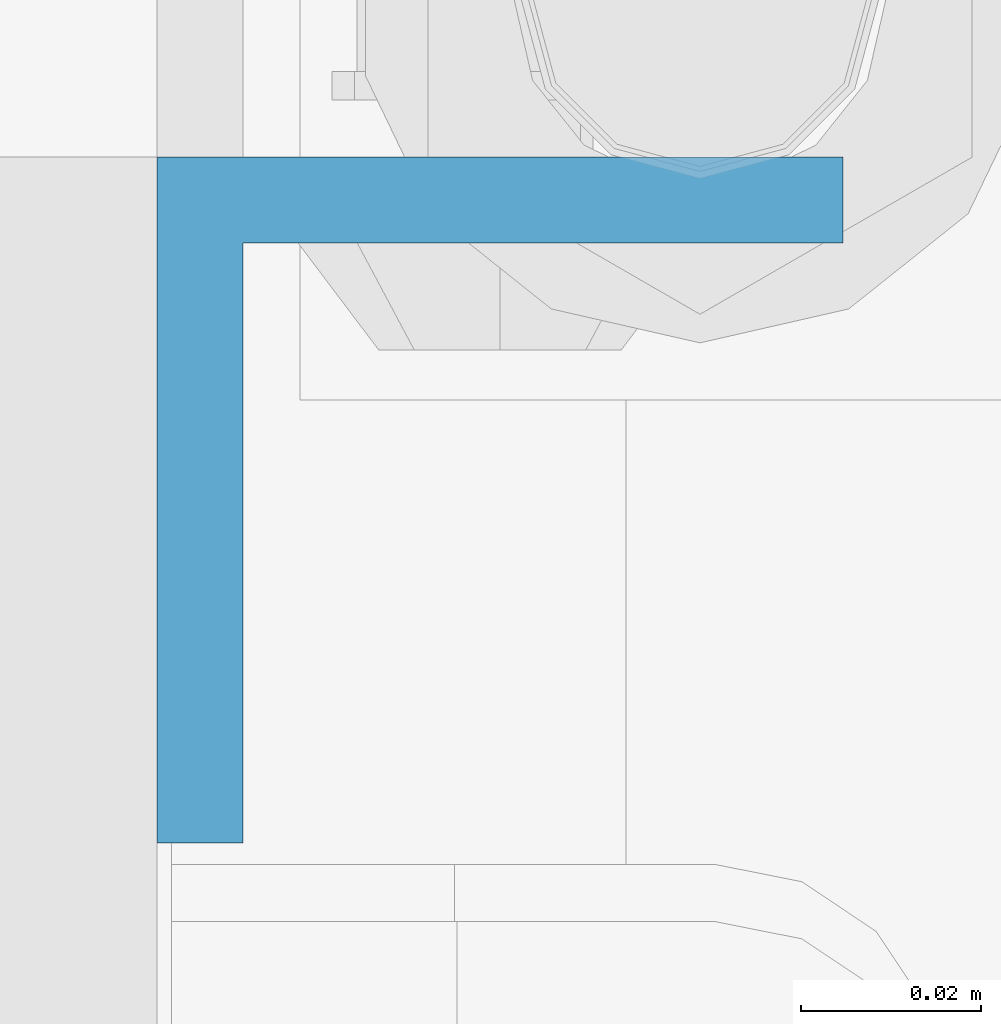
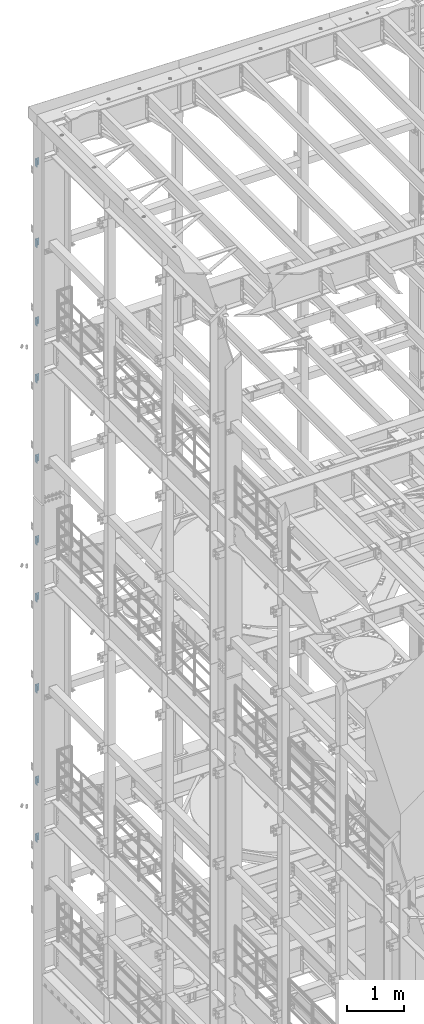
# One storey, part 853 of 1876: 10 columns, 2 elements without a shape of their own.
"""IFC2X3 building model written with IfcOpenShell, lengths in millimetres."""

import ifcopenshell
import ifcopenshell.guid

model = None  # the IFC model being written
_history = None  # IfcOwnerHistory: only IFC2X3 demands one
_inside = {}  # id of a spatial element -> (the spatial element, [elements in it])
_under = {}  # id of a project, library or spatial element -> (it, [spatial elements below it])
_declared = {}  # id of a project -> (the project, [libraries it declares])
_typed = {}  # id of a type object -> (the type object, [elements of that type])
_made_of = {}  # id of a material, layer set ... -> (it, [elements and type objects made of it])


def new_model(schema):
    """Start an empty IFC model of exactly this schema.

    Asked for "IFC4X3", IfcOpenShell would pick the latest addendum, in which some entities
    have other attributes; the version numbers below select the first issue.
    IFC2X3 requires an IfcOwnerHistory on every rooted entity: one is made here for all.
    """
    global model, _history
    if schema == "IFC4X3":
        model = ifcopenshell.file(schema_version=(4, 3, 0, 0))
    else:
        model = ifcopenshell.file(schema=schema)
    _inside.clear()
    _under.clear()
    _declared.clear()
    _typed.clear()
    _made_of.clear()
    _history = None
    if model.schema == "IFC2X3":
        org = make("IfcOrganization", Name="unknown")
        user = make(
            "IfcPersonAndOrganization",
            ThePerson=make("IfcPerson", FamilyName="unknown"),
            TheOrganization=org,
        )
        app = make(
            "IfcApplication",
            ApplicationDeveloper=org,
            Version="unknown",
            ApplicationFullName="unknown",
            ApplicationIdentifier="unknown",
        )
        _history = make(
            "IfcOwnerHistory",
            OwningUser=user,
            OwningApplication=app,
            ChangeAction="ADDED",
            CreationDate=0,
        )
    return model


def make(cls, **values):
    """One entity of the class cls with the attributes given. An attribute that is None is left unset."""
    return model.create_entity(
        cls, **{name: value for name, value in values.items() if value is not None}
    )


def rooted(cls, **values):
    """An entity with a GlobalId (a new one), such as an element, a storey or a relation."""
    return make(cls, GlobalId=ifcopenshell.guid.new(), OwnerHistory=_history, **values)


def si_unit(unit_type, name, prefix=None):
    """IfcSIUnit, for example si_unit("LENGTHUNIT", "METRE", prefix="MILLI")."""
    return make("IfcSIUnit", UnitType=unit_type, Prefix=prefix, Name=name)


def assignment(units):
    """IfcUnitAssignment: the units of a project."""
    return None if units is None else make("IfcUnitAssignment", Units=units)


def point(xyz):
    """IfcCartesianPoint."""
    return None if xyz is None else make("IfcCartesianPoint", Coordinates=xyz)


def direction(xyz):
    """IfcDirection."""
    return None if xyz is None else make("IfcDirection", DirectionRatios=xyz)


def frame(location, z_axis=None, x_axis=None):
    """IfcAxis2Placement3D, a coordinate frame: its origin and axes. An axis left out is left unset."""
    return make(
        "IfcAxis2Placement3D",
        Location=point(location),
        Axis=direction(z_axis),
        RefDirection=direction(x_axis),
    )


def origin_with_axes():
    """The frame at (0, 0, 0) with the z axis (0, 0, 1) and the x axis (1, 0, 0) written out."""
    return frame((0.0, 0.0, 0.0), z_axis=(0.0, 0.0, 1.0), x_axis=(1.0, 0.0, 0.0))


def place(relative_to, where):
    """IfcLocalPlacement: puts the frame where relative to a parent placement (None: the world)."""
    return make(
        "IfcLocalPlacement", PlacementRelTo=relative_to, RelativePlacement=where
    )


def context(
    kind, dimensions, precision=None, world=None, true_north=None, identifier=None
):
    """IfcGeometricRepresentationContext, for example the 3D "Model" context."""
    return make(
        "IfcGeometricRepresentationContext",
        ContextIdentifier=identifier,
        ContextType=kind,
        CoordinateSpaceDimension=dimensions,
        Precision=precision,
        WorldCoordinateSystem=world,
        TrueNorth=true_north,
    )


def subcontext(parent, identifier, kind, view, scale=None):
    """IfcGeometricRepresentationSubContext, for example "Body" below "Model"."""
    return make(
        "IfcGeometricRepresentationSubContext",
        ContextIdentifier=identifier,
        ContextType=kind,
        ParentContext=parent,
        TargetScale=scale,
        TargetView=view,
    )


def project(units=None, contexts=None):
    """IfcProject with its units and contexts."""
    return rooted(
        "IfcProject",
        Name="project",
        RepresentationContexts=contexts,
        UnitsInContext=assignment(units),
    )


def spatial(cls, under=None, at=None, **own):
    """A site, building, storey or space (cls), placed at a placement, below another one or the project."""
    s = rooted(cls, ObjectPlacement=at, **own)
    if under is not None:
        _under.setdefault(under.id(), (under, []))[1].append(s)
    return s


def faces_of(points, faces, orient=None, outer=None):
    """IfcFace entities. A face is a list of loops; a loop is a list of indices into points, from 0.

    orient and outer hold one flag for each loop. By default every Orientation is true, the
    first loop of a face is its IfcFaceOuterBound and the others are IfcFaceBound.
    """
    made = []
    for i, loops in enumerate(faces):
        bounds = []
        for j, loop in enumerate(loops):
            is_outer = j == 0 if outer is None else outer[i][j]
            bounds.append(
                make(
                    "IfcFaceOuterBound" if is_outer else "IfcFaceBound",
                    Bound=make("IfcPolyLoop", Polygon=[points[k] for k in loop]),
                    Orientation=True if orient is None else orient[i][j],
                )
            )
        made.append(make("IfcFace", Bounds=bounds))
    return made


def faceted_brep(points, faces, orient=None, outer=None, voids=None):
    """IfcFacetedBrep: a solid bounded by flat faces; with voids (closed shells), ...WithVoids."""
    shared = [point(p) for p in points]
    hull = make("IfcClosedShell", CfsFaces=faces_of(shared, faces, orient, outer))
    if voids is None:
        return make("IfcFacetedBrep", Outer=hull)
    return make(
        "IfcFacetedBrepWithVoids",
        Outer=hull,
        Voids=[
            make(cls, CfsFaces=faces_of(shared, fs, o, b)) for cls, fs, o, b in voids
        ],
    )


def shape(context_of_items, identifier, shape_type, items):
    """IfcShapeRepresentation: the items that make up one representation, for example the "Body"."""
    return make(
        "IfcShapeRepresentation",
        ContextOfItems=context_of_items,
        RepresentationIdentifier=identifier,
        RepresentationType=shape_type,
        Items=items,
    )


def material(Name=None, Category=None):
    """IfcMaterial."""
    return make("IfcMaterial", Name=Name, Category=Category)


def made_of(thing, what):
    """Note that an element or type object is made of a material, layer set ...; save() writes the relation."""
    if what is not None:
        _made_of.setdefault(what.id(), (what, []))[1].append(thing)
    return thing


def type_object(cls, material=None, **own):
    """A type object (cls), such as IfcWallType, which elements share."""
    return made_of(rooted(cls, **own), material)


def element(
    cls,
    number,
    at=None,
    inside=None,
    cuts=None,
    type_object=None,
    material=None,
    context=None,
    identifier="Body",
    shape_type=None,
    held_by="IfcProductDefinitionShape",
    body=None,
    shapes=None,
    **own,
):
    """One element of the class cls, such as IfcWall. Its Tag is "e" and its number.

    at: its placement. inside: the storey or other place that contains it. cuts: it is an
    opening in that element (IfcRelVoidsElement). A single representation is given by context,
    identifier, shape_type and body (its items); several are given by shapes. held_by: the class
    of the entity that holds the representations. save() writes the other relations.
    """
    e = rooted(cls, Tag="e%d" % number, ObjectPlacement=at, **own)
    if body is not None:
        shapes = [shape(context, identifier, shape_type, body)]
    if shapes is not None:
        e.Representation = make(held_by, Representations=shapes)
    if inside is not None:
        _inside.setdefault(inside.id(), (inside, []))[1].append(e)
    if cuts is not None:
        rooted(
            "IfcRelVoidsElement", RelatingBuildingElement=cuts, RelatedOpeningElement=e
        )
    if type_object is not None:
        _typed.setdefault(type_object.id(), (type_object, []))[1].append(e)
    return made_of(e, material)


def aggregate(whole, parts):
    """IfcRelAggregates: a whole, such as a stair, and the parts it consists of."""
    return rooted("IfcRelAggregates", RelatingObject=whole, RelatedObjects=parts)


def save(model, path):
    """Write the relations noted so far, then the file.

    IfcRelAggregates (storeys below a building ...), IfcRelContainedInSpatialStructure (elements
    in a storey), IfcRelDefinesByType, IfcRelAssociatesMaterial and IfcRelDeclares: one each for
    every whole, place, type object, material and project.
    """
    for whole, parts in _under.values():
        aggregate(whole, parts)
    for where, things in _inside.values():
        rooted(
            "IfcRelContainedInSpatialStructure",
            RelatedElements=things,
            RelatingStructure=where,
        )
    for kind, things in _typed.values():
        rooted("IfcRelDefinesByType", RelatedObjects=things, RelatingType=kind)
    for what, things in _made_of.values():
        rooted("IfcRelAssociatesMaterial", RelatedObjects=things, RelatingMaterial=what)
    for by, libraries in _declared.values():
        rooted("IfcRelDeclares", RelatingContext=by, RelatedDefinitions=libraries)
    model.write(path)


model = new_model("IFC2X3")

# Units and contexts
model_context = context("Model", 3, precision=1e-05, world=origin_with_axes())
body_context = subcontext(model_context, "Body", "Model", "MODEL_VIEW")
ifc_project = project(units=[si_unit("LENGTHUNIT", "METRE", prefix="MILLI"), si_unit("AREAUNIT", "SQUARE_METRE"), si_unit("VOLUMEUNIT", "CUBIC_METRE"), si_unit("MASSUNIT", "GRAM", prefix="KILO"), si_unit("TIMEUNIT", "SECOND"), si_unit("PLANEANGLEUNIT", "RADIAN"), si_unit("SOLIDANGLEUNIT", "STERADIAN"), si_unit("THERMODYNAMICTEMPERATUREUNIT", "DEGREE_CELSIUS"), si_unit("LUMINOUSINTENSITYUNIT", "LUMEN")], contexts=[model_context])

# Site, building, storey
site_placement = place(None, origin_with_axes())
site = spatial("IfcSite", under=ifc_project, at=site_placement, CompositionType="ELEMENT")
building_placement = place(site_placement, origin_with_axes())
building = spatial("IfcBuilding", under=site, at=building_placement, Name="Undefined", CompositionType="ELEMENT")
storey_placement = place(building_placement, origin_with_axes())
storey = spatial("IfcBuildingStorey", under=building, at=storey_placement, Name="Undefined", CompositionType="ELEMENT", Elevation=0.0)

# Assembly, columns
assembly_1_placement = place(storey_placement, origin_with_axes())
assembly_1 = element("IfcElementAssembly", 1, at=assembly_1_placement, inside=storey, Name="COLUMN", AssemblyPlace="NOTDEFINED", PredefinedType="RIGID_FRAME")
ifc_material = material(Name="STEEL/A36")
column_type = type_object("IfcColumnType", Name="L3X3X3/8", PredefinedType="NOTDEFINED")
column_1_placement = place(assembly_1_placement, frame((-212.725, 13838.2375, 21602.7), z_axis=(0.0, -1.0, 0.0), x_axis=(0.0, 0.0, 1.0)))
column_1 = element("IfcColumn", 2, at=column_1_placement, type_object=column_type, material=ifc_material, Name="ANGLE", ObjectType="L3X3X3/8", context=body_context, shape_type="Brep", body=[
    faceted_brep([(0.0, 38.1000000000004, -38.1), (0.0, 38.1000000000004, 38.1), (152.4, 38.1000000000004, 38.1), (152.4, 38.1000000000004, -38.1), (0.0, 28.5749999999998, 38.1), (152.4, 28.5749999999998, 38.1), (0.0, 28.5749999999998, -28.575), (152.4, 28.5749999999998, -28.575), (0.0, -38.1000000000004, -28.575), (152.4, -38.1000000000004, -28.575), (0.0, -38.1000000000004, -38.1), (152.4, -38.1000000000004, -38.1)], [[[0, 1, 2, 3]], [[1, 4, 5, 2]], [[4, 6, 7, 5]], [[6, 8, 9, 7]], [[8, 10, 11, 9]], [[10, 0, 3, 11]], [[5, 7, 9, 11, 3, 2]], [[10, 8, 6, 4, 1, 0]]]),
])
column_2_placement = place(assembly_1_placement, frame((-212.725, 13838.2375, 19881.85), z_axis=(0.0, -1.0, 0.0), x_axis=(0.0, 0.0, 1.0)))
column_2 = element("IfcColumn", 3, at=column_2_placement, type_object=column_type, material=ifc_material, Name="ANGLE", ObjectType="L3X3X3/8", context=body_context, shape_type="Brep", body=[
    faceted_brep([(0.0, 38.1000000000004, -38.1), (0.0, 38.1000000000004, 38.1), (152.4, 38.1000000000004, 38.1), (152.4, 38.1000000000004, -38.1), (0.0, 28.5749999999998, 38.1), (152.4, 28.5749999999998, 38.1), (0.0, 28.5749999999998, -28.575), (152.4, 28.5749999999998, -28.575), (0.0, -38.1000000000004, -28.575), (152.4, -38.1000000000004, -28.575), (0.0, -38.1000000000004, -38.1), (152.4, -38.1000000000004, -38.1)], [[[0, 1, 2, 3]], [[1, 4, 5, 2]], [[4, 6, 7, 5]], [[6, 8, 9, 7]], [[8, 10, 11, 9]], [[10, 0, 3, 11]], [[5, 7, 9, 11, 3, 2]], [[10, 8, 6, 4, 1, 0]]]),
])
column_3_placement = place(assembly_1_placement, frame((-212.725, 13838.2375, 18199.1), z_axis=(0.0, -1.0, 0.0), x_axis=(0.0, 0.0, 1.0)))
column_3 = element("IfcColumn", 4, at=column_3_placement, type_object=column_type, material=ifc_material, Name="ANGLE", ObjectType="L3X3X3/8", context=body_context, shape_type="Brep", body=[
    faceted_brep([(0.0, 38.1000000000004, -38.1), (0.0, 38.1000000000004, 38.1), (152.4, 38.1000000000004, 38.1), (152.4, 38.1000000000004, -38.1), (0.0, 28.5749999999998, 38.1), (152.4, 28.5749999999998, 38.1), (0.0, 28.5749999999998, -28.575), (152.4, 28.5749999999998, -28.575), (0.0, -38.1000000000004, -28.575), (152.4, -38.1000000000004, -28.575), (0.0, -38.1000000000004, -38.1), (152.4, -38.1000000000004, -38.1)], [[[0, 1, 2, 3]], [[1, 4, 5, 2]], [[4, 6, 7, 5]], [[6, 8, 9, 7]], [[8, 10, 11, 9]], [[10, 0, 3, 11]], [[5, 7, 9, 11, 3, 2]], [[10, 8, 6, 4, 1, 0]]]),
])
column_4_placement = place(assembly_1_placement, frame((-212.725, 13838.2375, 16979.9), z_axis=(0.0, -1.0, 0.0), x_axis=(0.0, 0.0, 1.0)))
column_4 = element("IfcColumn", 5, at=column_4_placement, type_object=column_type, material=ifc_material, Name="ANGLE", ObjectType="L3X3X3/8", context=body_context, shape_type="Brep", body=[
    faceted_brep([(0.0, 38.1000000000004, -38.1), (0.0, 38.1000000000004, 38.1), (152.4, 38.1000000000004, 38.1), (152.4, 38.1000000000004, -38.1), (0.0, 28.5749999999998, 38.1), (152.4, 28.5749999999998, 38.1), (0.0, 28.5749999999998, -28.575), (152.4, 28.5749999999998, -28.575), (0.0, -38.1000000000004, -28.575), (152.4, -38.1000000000004, -28.575), (0.0, -38.1000000000004, -38.1), (152.4, -38.1000000000004, -38.1)], [[[0, 1, 2, 3]], [[1, 4, 5, 2]], [[4, 6, 7, 5]], [[6, 8, 9, 7]], [[8, 10, 11, 9]], [[10, 0, 3, 11]], [[5, 7, 9, 11, 3, 2]], [[10, 8, 6, 4, 1, 0]]]),
])
column_5_placement = place(assembly_1_placement, frame((-212.725, 13838.2375, 15259.05), z_axis=(0.0, -1.0, 0.0), x_axis=(0.0, 0.0, 1.0)))
column_5 = element("IfcColumn", 6, at=column_5_placement, type_object=column_type, material=ifc_material, Name="ANGLE", ObjectType="L3X3X3/8", context=body_context, shape_type="Brep", body=[
    faceted_brep([(0.0, 38.1000000000004, -38.1), (0.0, 38.1000000000004, 38.1), (152.4, 38.1000000000004, 38.1), (152.4, 38.1000000000004, -38.1), (0.0, 28.5749999999998, 38.1), (152.4, 28.5749999999998, 38.1), (0.0, 28.5749999999998, -28.575), (152.4, 28.5749999999998, -28.575), (0.0, -38.1000000000004, -28.575), (152.4, -38.1000000000004, -28.575), (0.0, -38.1000000000004, -38.1), (152.4, -38.1000000000004, -38.1)], [[[0, 1, 2, 3]], [[1, 4, 5, 2]], [[4, 6, 7, 5]], [[6, 8, 9, 7]], [[8, 10, 11, 9]], [[10, 0, 3, 11]], [[5, 7, 9, 11, 3, 2]], [[10, 8, 6, 4, 1, 0]]]),
])
aggregate(assembly_1, [column_1, column_2, column_3, column_4, column_5])

assembly_2_placement = place(storey_placement, origin_with_axes())
assembly_2 = element("IfcElementAssembly", 7, at=assembly_2_placement, inside=storey, Name="COLUMN", AssemblyPlace="NOTDEFINED", PredefinedType="RIGID_FRAME")
column_6_placement = place(assembly_2_placement, frame((-212.725, 13838.2375, 13512.8), z_axis=(0.0, -1.0, 0.0), x_axis=(0.0, 0.0, 1.0)))
column_6 = element("IfcColumn", 8, at=column_6_placement, type_object=column_type, material=ifc_material, Name="ANGLE", ObjectType="L3X3X3/8", context=body_context, shape_type="Brep", body=[
    faceted_brep([(0.0, 38.1000000000004, -38.1), (0.0, 38.1000000000004, 38.1), (152.4, 38.1000000000004, 38.1), (152.4, 38.1000000000004, -38.1), (0.0, 28.5749999999998, 38.1), (152.4, 28.5749999999998, 38.1), (0.0, 28.5749999999998, -28.575), (152.4, 28.5749999999998, -28.575), (0.0, -38.1000000000004, -28.575), (152.4, -38.1000000000004, -28.575), (0.0, -38.1000000000004, -38.1), (152.4, -38.1000000000004, -38.1)], [[[0, 1, 2, 3]], [[1, 4, 5, 2]], [[4, 6, 7, 5]], [[6, 8, 9, 7]], [[8, 10, 11, 9]], [[10, 0, 3, 11]], [[5, 7, 9, 11, 3, 2]], [[10, 8, 6, 4, 1, 0]]]),
])
column_7_placement = place(assembly_2_placement, frame((-212.725, 13838.2375, 12293.6), z_axis=(0.0, -1.0, 0.0), x_axis=(0.0, 0.0, 1.0)))
column_7 = element("IfcColumn", 9, at=column_7_placement, type_object=column_type, material=ifc_material, Name="ANGLE", ObjectType="L3X3X3/8", context=body_context, shape_type="Brep", body=[
    faceted_brep([(0.0, 38.1000000000004, -38.1), (0.0, 38.1000000000004, 38.1), (152.4, 38.1000000000004, 38.1), (152.4, 38.1000000000004, -38.1), (0.0, 28.5749999999998, 38.1), (152.4, 28.5749999999998, 38.1), (0.0, 28.5749999999998, -28.575), (152.4, 28.5749999999998, -28.575), (0.0, -38.1000000000004, -28.575), (152.4, -38.1000000000004, -28.575), (0.0, -38.1000000000004, -38.1), (152.4, -38.1000000000004, -38.1)], [[[0, 1, 2, 3]], [[1, 4, 5, 2]], [[4, 6, 7, 5]], [[6, 8, 9, 7]], [[8, 10, 11, 9]], [[10, 0, 3, 11]], [[5, 7, 9, 11, 3, 2]], [[10, 8, 6, 4, 1, 0]]]),
])
column_8_placement = place(assembly_2_placement, frame((-212.725, 13838.2375, 10344.15), z_axis=(0.0, -1.0, 0.0), x_axis=(0.0, 0.0, 1.0)))
column_8 = element("IfcColumn", 10, at=column_8_placement, type_object=column_type, material=ifc_material, Name="ANGLE", ObjectType="L3X3X3/8", context=body_context, shape_type="Brep", body=[
    faceted_brep([(0.0, 38.1000000000004, -38.1), (0.0, 38.1000000000004, 38.1), (152.4, 38.1000000000004, 38.1), (152.4, 38.1000000000004, -38.1), (0.0, 28.5749999999998, 38.1), (152.4, 28.5749999999998, 38.1), (0.0, 28.5749999999998, -28.575), (152.4, 28.5749999999998, -28.575), (0.0, -38.1000000000004, -28.575), (152.4, -38.1000000000004, -28.575), (0.0, -38.1000000000004, -38.1), (152.4, -38.1000000000004, -38.1)], [[[0, 1, 2, 3]], [[1, 4, 5, 2]], [[4, 6, 7, 5]], [[6, 8, 9, 7]], [[8, 10, 11, 9]], [[10, 0, 3, 11]], [[5, 7, 9, 11, 3, 2]], [[10, 8, 6, 4, 1, 0]]]),
])
column_9_placement = place(assembly_2_placement, frame((-212.725, 13838.2375, 8369.3), z_axis=(0.0, -1.0, 0.0), x_axis=(0.0, 0.0, 1.0)))
column_9 = element("IfcColumn", 11, at=column_9_placement, type_object=column_type, material=ifc_material, Name="ANGLE", ObjectType="L3X3X3/8", context=body_context, shape_type="Brep", body=[
    faceted_brep([(0.0, 38.1000000000004, -38.1), (0.0, 38.1000000000004, 38.1), (152.4, 38.1000000000004, 38.1), (152.4, 38.1000000000004, -38.1), (0.0, 28.5749999999998, 38.1), (152.4, 28.5749999999998, 38.1), (0.0, 28.5749999999998, -28.575), (152.4, 28.5749999999998, -28.575), (0.0, -38.1000000000004, -28.575), (152.4, -38.1000000000004, -28.575), (0.0, -38.1000000000004, -38.1), (152.4, -38.1000000000004, -38.1)], [[[0, 1, 2, 3]], [[1, 4, 5, 2]], [[4, 6, 7, 5]], [[6, 8, 9, 7]], [[8, 10, 11, 9]], [[10, 0, 3, 11]], [[5, 7, 9, 11, 3, 2]], [[10, 8, 6, 4, 1, 0]]]),
])
column_10_placement = place(assembly_2_placement, frame((-212.725, 13838.2375, 7150.1), z_axis=(0.0, -1.0, 0.0), x_axis=(0.0, 0.0, 1.0)))
column_10 = element("IfcColumn", 12, at=column_10_placement, type_object=column_type, material=ifc_material, Name="ANGLE", ObjectType="L3X3X3/8", context=body_context, shape_type="Brep", body=[
    faceted_brep([(0.0, 38.1000000000004, -38.1), (0.0, 38.1000000000004, 38.1), (152.4, 38.1000000000004, 38.1), (152.4, 38.1000000000004, -38.1), (0.0, 28.5749999999998, 38.1), (152.4, 28.5749999999998, 38.1), (0.0, 28.5749999999998, -28.575), (152.4, 28.5749999999998, -28.575), (0.0, -38.1000000000004, -28.575), (152.4, -38.1000000000004, -28.575), (0.0, -38.1000000000004, -38.1), (152.4, -38.1000000000004, -38.1)], [[[0, 1, 2, 3]], [[1, 4, 5, 2]], [[4, 6, 7, 5]], [[6, 8, 9, 7]], [[8, 10, 11, 9]], [[10, 0, 3, 11]], [[5, 7, 9, 11, 3, 2]], [[10, 8, 6, 4, 1, 0]]]),
])
aggregate(assembly_2, [column_6, column_7, column_8, column_9, column_10])

save(model, "model.ifc")
